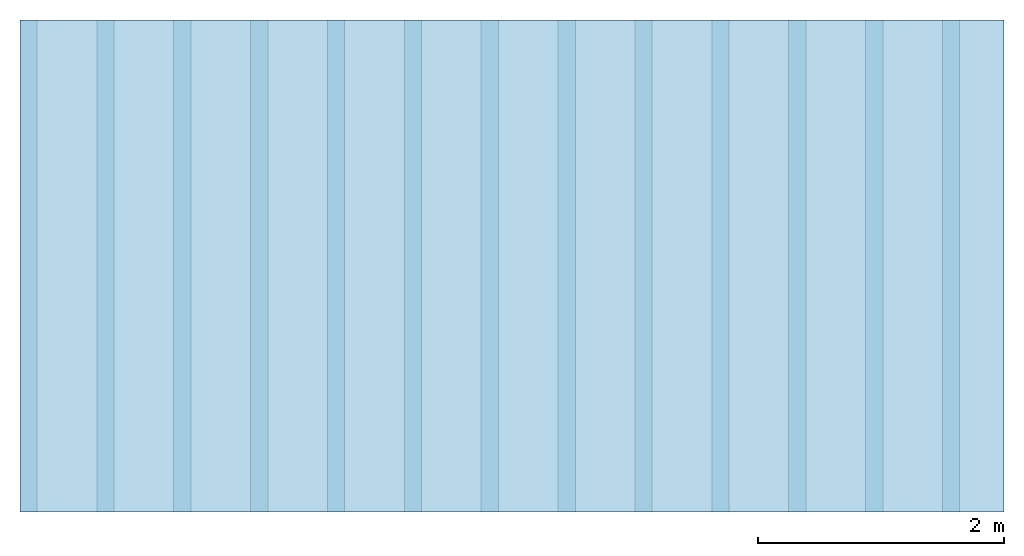
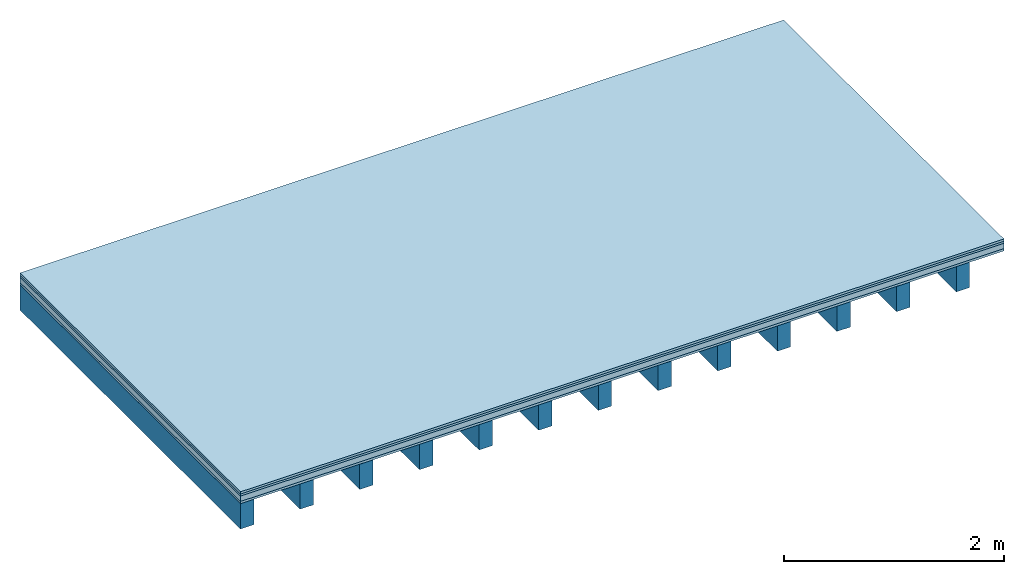
# One storey: 4 plates, 1 member, 1 element without a shape of its own.
"""IFC4 building model written with IfcOpenShell, lengths in metres."""

from ifc_helpers import new_model, si_unit, derived_unit, direction, frame, frame_2d, origin, origin_with_axes, place, context, project, spatial, rectangle, extrude, material, layer, layer_set, type_object, element, aggregate, save


model = new_model("IFC4")

# Units and contexts
plan_context = context("Plan", 3, precision=1e-05, world=origin(), true_north=direction((0.0, 1.0)))
model_context = context("Model", 3, precision=1e-05, world=origin(), true_north=direction((0.0, 1.0)))
ifc_project = project(units=[si_unit("LENGTHUNIT", "METRE"), derived_unit("SOUNDPRESSUREUNIT", [(si_unit("PRESSUREUNIT", "PASCAL", prefix="MICRO"), 0)]), si_unit("ENERGYUNIT", "JOULE", prefix="MEGA"), si_unit("MASSUNIT", "GRAM", prefix="KILO"), derived_unit("THERMALTRANSMITTANCEUNIT", [(si_unit("POWERUNIT", "WATT"), 1), (si_unit("AREAUNIT", "SQUARE_METRE"), -1), (si_unit("THERMODYNAMICTEMPERATUREUNIT", "KELVIN"), -1)]), derived_unit("AREADENSITYUNIT", [(si_unit("MASSUNIT", "GRAM", prefix="KILO"), 1), (si_unit("AREAUNIT", "SQUARE_METRE"), -1)]), derived_unit("USERDEFINED", [(si_unit("ENERGYUNIT", "JOULE", prefix="MEGA"), 1), (si_unit("AREAUNIT", "SQUARE_METRE"), -1)])], contexts=[plan_context, model_context])

# Site, building, storey
site = spatial("IfcSite", under=ifc_project)
building_placement = place(None, origin())
building = spatial("IfcBuilding", under=site, at=building_placement)
storey_placement = place(building_placement, origin())
storey = spatial("IfcBuildingStorey", under=building, at=storey_placement)

# Slab, member, plates
ifc_material_1 = material(Name="Floor heating system Therm38 longitudinal", Category="03.007")
ifc_layer_1 = layer(ifc_material_1, 0.025, Name="On-material")
ifc_material_2 = material(Category="10.009")
ifc_layer_2 = layer(ifc_material_2, 0.022, Name="Impact sound insulation")
ifc_material_3 = material(Name="Cement panels, glued on sub-floor", Category="02.007")
ifc_layer_3 = layer(ifc_material_3, 0.06, Name="on Supporting structure")
ifc_material_4 = material(Category="07.001")
ifc_layer_4 = layer(ifc_material_4, 0.025, Name="Sub-floor")
ifc_material_5 = material(Name="of the art")
ifc_layer_5 = layer(ifc_material_5, 0.0, Name="Bond")
ifc_layer_6 = layer(None, 0.28, Name="Supporting structure")
ifc_layer_set = layer_set([ifc_layer_1, ifc_layer_2, ifc_layer_3, ifc_layer_4, ifc_layer_5, ifc_layer_6])
slab_type = type_object("IfcSlabType", Name="A0229", PredefinedType="NOTDEFINED", material=ifc_layer_set)
slab_placement = place(None, frame((0.0, 0.0, 0.0), z_axis=(0.0, 0.0, -1.0), x_axis=(1.0, 0.0, 0.0)))
slab = element("IfcSlab", 1, at=slab_placement, inside=storey, type_object=slab_type, material=ifc_layer_set, Name="Slab #1")
ifc_material_6 = material()
member_placement = place(slab_placement, origin())
member = element("IfcMember", 2, at=member_placement, material=ifc_material_6, Name="Supporting structure", context=plan_context, shape_type="SweptSolid", body=[
    extrude(rectangle(XDim=0.14, YDim=0.28, at=frame_2d((0.07, 0.14), x_axis=(1.0, 0.0))), frame((0.0, 4.0, 0.132), z_axis=(0.0, -1.0, 0.0), x_axis=(1.0, 0.0, 0.0)), (0.0, 0.0, 1.0), 4.0),
    extrude(rectangle(XDim=0.14, YDim=0.28, at=frame_2d((0.07, 0.14), x_axis=(1.0, 0.0))), frame((0.625, 4.0, 0.132), z_axis=(0.0, -1.0, 0.0), x_axis=(1.0, 0.0, 0.0)), (0.0, 0.0, 1.0), 4.0),
    extrude(rectangle(XDim=0.14, YDim=0.28, at=frame_2d((0.07, 0.14), x_axis=(1.0, 0.0))), frame((1.25, 4.0, 0.132), z_axis=(0.0, -1.0, 0.0), x_axis=(1.0, 0.0, 0.0)), (0.0, 0.0, 1.0), 4.0),
    extrude(rectangle(XDim=0.14, YDim=0.28, at=frame_2d((0.07, 0.14), x_axis=(1.0, 0.0))), frame((1.875, 4.0, 0.132), z_axis=(0.0, -1.0, 0.0), x_axis=(1.0, 0.0, 0.0)), (0.0, 0.0, 1.0), 4.0),
    extrude(rectangle(XDim=0.14, YDim=0.28, at=frame_2d((0.07, 0.14), x_axis=(1.0, 0.0))), frame((2.5, 4.0, 0.132), z_axis=(0.0, -1.0, 0.0), x_axis=(1.0, 0.0, 0.0)), (0.0, 0.0, 1.0), 4.0),
    extrude(rectangle(XDim=0.14, YDim=0.28, at=frame_2d((0.07, 0.14), x_axis=(1.0, 0.0))), frame((3.125, 4.0, 0.132), z_axis=(0.0, -1.0, 0.0), x_axis=(1.0, 0.0, 0.0)), (0.0, 0.0, 1.0), 4.0),
    extrude(rectangle(XDim=0.14, YDim=0.28, at=frame_2d((0.07, 0.14), x_axis=(1.0, 0.0))), frame((3.75, 4.0, 0.132), z_axis=(0.0, -1.0, 0.0), x_axis=(1.0, 0.0, 0.0)), (0.0, 0.0, 1.0), 4.0),
    extrude(rectangle(XDim=0.14, YDim=0.28, at=frame_2d((0.07, 0.14), x_axis=(1.0, 0.0))), frame((4.375, 4.0, 0.132), z_axis=(0.0, -1.0, 0.0), x_axis=(1.0, 0.0, 0.0)), (0.0, 0.0, 1.0), 4.0),
    extrude(rectangle(XDim=0.14, YDim=0.28, at=frame_2d((0.07, 0.14), x_axis=(1.0, 0.0))), frame((5.0, 4.0, 0.132), z_axis=(0.0, -1.0, 0.0), x_axis=(1.0, 0.0, 0.0)), (0.0, 0.0, 1.0), 4.0),
    extrude(rectangle(XDim=0.14, YDim=0.28, at=frame_2d((0.07, 0.14), x_axis=(1.0, 0.0))), frame((5.625, 4.0, 0.132), z_axis=(0.0, -1.0, 0.0), x_axis=(1.0, 0.0, 0.0)), (0.0, 0.0, 1.0), 4.0),
    extrude(rectangle(XDim=0.14, YDim=0.28, at=frame_2d((0.07, 0.14), x_axis=(1.0, 0.0))), frame((6.25, 4.0, 0.132), z_axis=(0.0, -1.0, 0.0), x_axis=(1.0, 0.0, 0.0)), (0.0, 0.0, 1.0), 4.0),
    extrude(rectangle(XDim=0.14, YDim=0.28, at=frame_2d((0.07, 0.14), x_axis=(1.0, 0.0))), frame((6.875, 4.0, 0.132), z_axis=(0.0, -1.0, 0.0), x_axis=(1.0, 0.0, 0.0)), (0.0, 0.0, 1.0), 4.0),
    extrude(rectangle(XDim=0.14, YDim=0.28, at=frame_2d((0.07, 0.14), x_axis=(1.0, 0.0))), frame((7.5, 4.0, 0.132), z_axis=(0.0, -1.0, 0.0), x_axis=(1.0, 0.0, 0.0)), (0.0, 0.0, 1.0), 4.0),
])
plate_1_placement = place(slab_placement, origin())
plate_1 = element("IfcPlate", 3, at=plate_1_placement, material=ifc_material_1, Name="On-material", context=plan_context, shape_type="SweptSolid", body=[
    extrude(rectangle(XDim=8.0, YDim=4.0, at=frame_2d((4.0, 2.0), x_axis=(1.0, 0.0))), origin_with_axes(), (0.0, 0.0, 1.0), 0.025),
])
plate_2_placement = place(slab_placement, origin())
plate_2 = element("IfcPlate", 4, at=plate_2_placement, material=ifc_material_2, Name="Impact sound insulation", context=plan_context, shape_type="SweptSolid", body=[
    extrude(rectangle(XDim=8.0, YDim=4.0, at=frame_2d((4.0, 2.0), x_axis=(1.0, 0.0))), frame((0.0, 0.0, 0.025), z_axis=(0.0, 0.0, 1.0), x_axis=(1.0, 0.0, 0.0)), (0.0, 0.0, 1.0), 0.022),
])
plate_3_placement = place(slab_placement, origin())
plate_3 = element("IfcPlate", 5, at=plate_3_placement, material=ifc_material_3, Name="on Supporting structure", context=plan_context, shape_type="SweptSolid", body=[
    extrude(rectangle(XDim=8.0, YDim=4.0, at=frame_2d((4.0, 2.0), x_axis=(1.0, 0.0))), frame((0.0, 0.0, 0.047), z_axis=(0.0, 0.0, 1.0), x_axis=(1.0, 0.0, 0.0)), (0.0, 0.0, 1.0), 0.06),
])
plate_4_placement = place(slab_placement, origin())
plate_4 = element("IfcPlate", 6, at=plate_4_placement, material=ifc_material_4, Name="Sub-floor", context=plan_context, shape_type="SweptSolid", body=[
    extrude(rectangle(XDim=8.0, YDim=4.0, at=frame_2d((4.0, 2.0), x_axis=(1.0, 0.0))), frame((0.0, 0.0, 0.107), z_axis=(0.0, 0.0, 1.0), x_axis=(1.0, 0.0, 0.0)), (0.0, 0.0, 1.0), 0.025),
])
aggregate(slab, [plate_1, plate_2, plate_3, plate_4, member])

save(model, "model.ifc")
